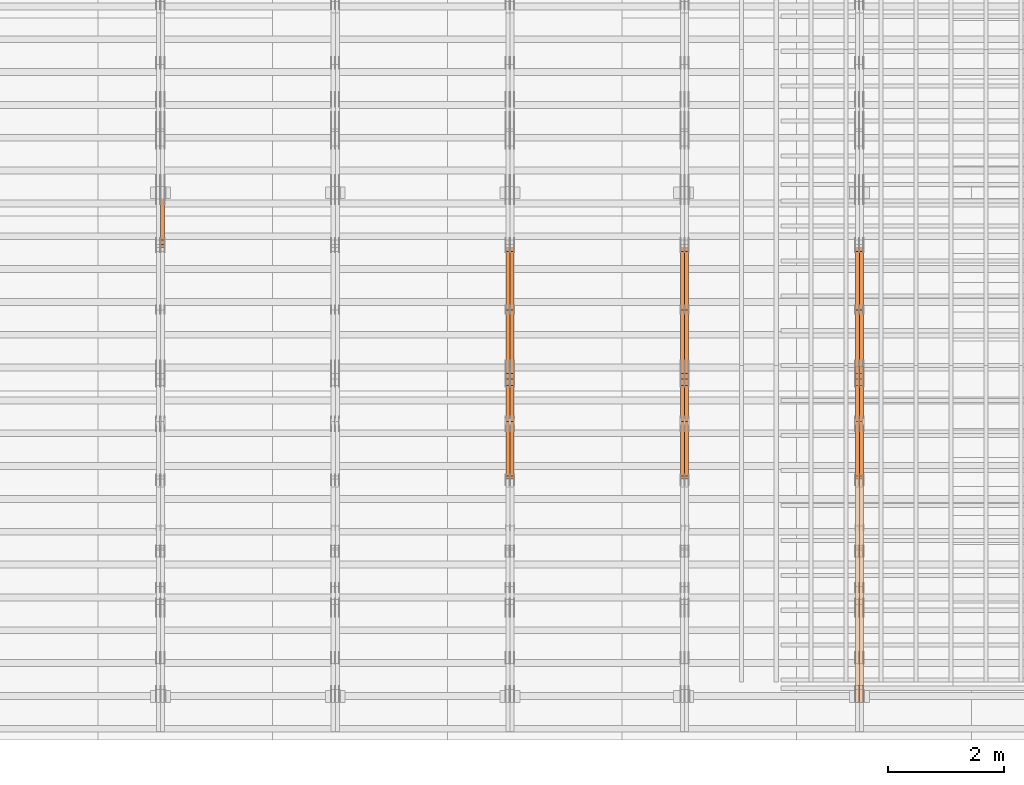
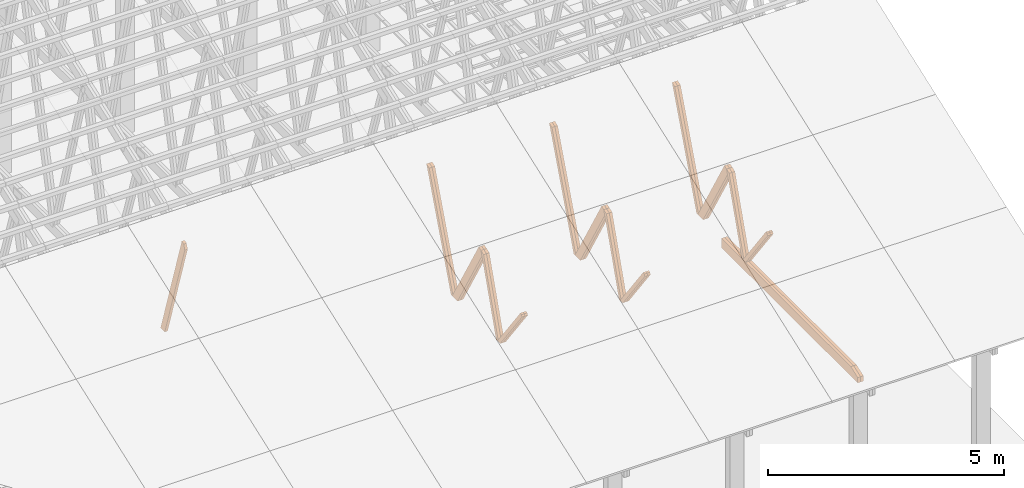
# One storey, part 48 of 189: 27 proxies.
"""IFC2X3 building model written with IfcOpenShell, lengths in millimetres."""

import ifcopenshell
import ifcopenshell.guid

model = None  # the IFC model being written
_history = None  # IfcOwnerHistory: only IFC2X3 demands one
_inside = {}  # id of a spatial element -> (the spatial element, [elements in it])
_under = {}  # id of a project, library or spatial element -> (it, [spatial elements below it])
_declared = {}  # id of a project -> (the project, [libraries it declares])
_typed = {}  # id of a type object -> (the type object, [elements of that type])
_made_of = {}  # id of a material, layer set ... -> (it, [elements and type objects made of it])


def new_model(schema):
    """Start an empty IFC model of exactly this schema.

    Asked for "IFC4X3", IfcOpenShell would pick the latest addendum, in which some entities
    have other attributes; the version numbers below select the first issue.
    IFC2X3 requires an IfcOwnerHistory on every rooted entity: one is made here for all.
    """
    global model, _history
    if schema == "IFC4X3":
        model = ifcopenshell.file(schema_version=(4, 3, 0, 0))
    else:
        model = ifcopenshell.file(schema=schema)
    _inside.clear()
    _under.clear()
    _declared.clear()
    _typed.clear()
    _made_of.clear()
    _history = None
    if model.schema == "IFC2X3":
        org = make("IfcOrganization", Name="unknown")
        user = make(
            "IfcPersonAndOrganization",
            ThePerson=make("IfcPerson", FamilyName="unknown"),
            TheOrganization=org,
        )
        app = make(
            "IfcApplication",
            ApplicationDeveloper=org,
            Version="unknown",
            ApplicationFullName="unknown",
            ApplicationIdentifier="unknown",
        )
        _history = make(
            "IfcOwnerHistory",
            OwningUser=user,
            OwningApplication=app,
            ChangeAction="ADDED",
            CreationDate=0,
        )
    return model


def make(cls, **values):
    """One entity of the class cls with the attributes given. An attribute that is None is left unset."""
    return model.create_entity(
        cls, **{name: value for name, value in values.items() if value is not None}
    )


def entity(cls, *values):
    """Any entity or typed value of the class cls, its attributes in the order of the schema. None: left unset."""
    e = model.create_entity(cls)
    for i, value in enumerate(values):
        if value is not None:
            e[i] = value
    return e


def rooted(cls, **values):
    """An entity with a GlobalId (a new one), such as an element, a storey or a relation."""
    return make(cls, GlobalId=ifcopenshell.guid.new(), OwnerHistory=_history, **values)


def si_unit(unit_type, name, prefix=None):
    """IfcSIUnit, for example si_unit("LENGTHUNIT", "METRE", prefix="MILLI")."""
    return make("IfcSIUnit", UnitType=unit_type, Prefix=prefix, Name=name)


def converted_unit(unit_type, name, factor, base, dimensions=None, offset=None):
    """IfcConversionBasedUnit, such as the inch: factor (a typed value) times the base unit."""
    return make(
        "IfcConversionBasedUnit"
        if offset is None
        else "IfcConversionBasedUnitWithOffset",
        ConversionOffset=offset,
        Dimensions=None
        if dimensions is None
        else entity("IfcDimensionalExponents", *dimensions),
        UnitType=unit_type,
        Name=name,
        ConversionFactor=make(
            "IfcMeasureWithUnit", ValueComponent=factor, UnitComponent=base
        ),
    )


def derived_unit(unit_type, elements):
    """IfcDerivedUnit: a product of units, each with its exponent."""
    return make(
        "IfcDerivedUnit",
        Elements=[
            make("IfcDerivedUnitElement", Unit=unit, Exponent=power)
            for unit, power in elements
        ],
        UnitType=unit_type,
    )


def assignment(units):
    """IfcUnitAssignment: the units of a project."""
    return None if units is None else make("IfcUnitAssignment", Units=units)


def point(xyz):
    """IfcCartesianPoint."""
    return None if xyz is None else make("IfcCartesianPoint", Coordinates=xyz)


def direction(xyz):
    """IfcDirection."""
    return None if xyz is None else make("IfcDirection", DirectionRatios=xyz)


def frame(location, z_axis=None, x_axis=None):
    """IfcAxis2Placement3D, a coordinate frame: its origin and axes. An axis left out is left unset."""
    return make(
        "IfcAxis2Placement3D",
        Location=point(location),
        Axis=direction(z_axis),
        RefDirection=direction(x_axis),
    )


def origin():
    """The frame at (0, 0, 0) with its axes left unset."""
    return frame((0.0, 0.0, 0.0))


def place(relative_to, where):
    """IfcLocalPlacement: puts the frame where relative to a parent placement (None: the world)."""
    return make(
        "IfcLocalPlacement", PlacementRelTo=relative_to, RelativePlacement=where
    )


def context(
    kind, dimensions, precision=None, world=None, true_north=None, identifier=None
):
    """IfcGeometricRepresentationContext, for example the 3D "Model" context."""
    return make(
        "IfcGeometricRepresentationContext",
        ContextIdentifier=identifier,
        ContextType=kind,
        CoordinateSpaceDimension=dimensions,
        Precision=precision,
        WorldCoordinateSystem=world,
        TrueNorth=true_north,
    )


def subcontext(parent, identifier, kind, view, scale=None):
    """IfcGeometricRepresentationSubContext, for example "Body" below "Model"."""
    return make(
        "IfcGeometricRepresentationSubContext",
        ContextIdentifier=identifier,
        ContextType=kind,
        ParentContext=parent,
        TargetScale=scale,
        TargetView=view,
    )


def project(units=None, contexts=None):
    """IfcProject with its units and contexts."""
    return rooted(
        "IfcProject",
        Name="project",
        RepresentationContexts=contexts,
        UnitsInContext=assignment(units),
    )


def spatial(cls, under=None, at=None, **own):
    """A site, building, storey or space (cls), placed at a placement, below another one or the project."""
    s = rooted(cls, ObjectPlacement=at, **own)
    if under is not None:
        _under.setdefault(under.id(), (under, []))[1].append(s)
    return s


def polyline(points):
    """IfcPolyline through the points."""
    return make("IfcPolyline", Points=[point(p) for p in points])


def outline(outer, holes=None, kind="AREA"):
    """IfcArbitraryClosedProfileDef: a profile drawn as a closed curve; with holes, ...WithVoids."""
    if holes is None:
        return make("IfcArbitraryClosedProfileDef", ProfileType=kind, OuterCurve=outer)
    return make(
        "IfcArbitraryProfileDefWithVoids",
        ProfileType=kind,
        OuterCurve=outer,
        InnerCurves=holes,
    )


def extrude(swept, where, along, depth):
    """IfcExtrudedAreaSolid: the profile swept, set in the frame where, extruded along a direction by depth."""
    return make(
        "IfcExtrudedAreaSolid",
        SweptArea=swept,
        Position=where,
        ExtrudedDirection=direction(along),
        Depth=depth,
    )


def shape(context_of_items, identifier, shape_type, items):
    """IfcShapeRepresentation: the items that make up one representation, for example the "Body"."""
    return make(
        "IfcShapeRepresentation",
        ContextOfItems=context_of_items,
        RepresentationIdentifier=identifier,
        RepresentationType=shape_type,
        Items=items,
    )


def source(mapping_origin, context_of_items, identifier, shape_type, items):
    """IfcRepresentationMap: a shape defined once, which mapped items show again and again."""
    return make(
        "IfcRepresentationMap",
        MappingOrigin=mapping_origin,
        MappedRepresentation=shape(context_of_items, identifier, shape_type, items),
    )


def transform(
    local_origin,
    x_axis=None,
    y_axis=None,
    z_axis=None,
    scale=None,
    scale2=None,
    scale3=None,
    uniform=True,
):
    """IfcCartesianTransformationOperator3D, or its non-uniform kind. x_axis, y_axis, z_axis: its Axis1, 2, 3."""
    if uniform:
        return make(
            "IfcCartesianTransformationOperator3D",
            Axis1=direction(x_axis),
            Axis2=direction(y_axis),
            LocalOrigin=point(local_origin),
            Scale=scale,
            Axis3=direction(z_axis),
        )
    return make(
        "IfcCartesianTransformationOperator3DnonUniform",
        Axis1=direction(x_axis),
        Axis2=direction(y_axis),
        LocalOrigin=point(local_origin),
        Scale=scale,
        Axis3=direction(z_axis),
        Scale2=scale2,
        Scale3=scale3,
    )


def mapped(mapping_source, mapping_target):
    """IfcMappedItem: shows the shape of a source again, moved by a transform."""
    return make(
        "IfcMappedItem", MappingSource=mapping_source, MappingTarget=mapping_target
    )


def material(Name=None, Category=None):
    """IfcMaterial."""
    return make("IfcMaterial", Name=Name, Category=Category)


def made_of(thing, what):
    """Note that an element or type object is made of a material, layer set ...; save() writes the relation."""
    if what is not None:
        _made_of.setdefault(what.id(), (what, []))[1].append(thing)
    return thing


def type_object(cls, material=None, **own):
    """A type object (cls), such as IfcWallType, which elements share."""
    return made_of(rooted(cls, **own), material)


def type_shapes(of_type, sources):
    """Give a type object the sources (RepresentationMaps) that its elements show as mapped items."""
    of_type.RepresentationMaps = sources


def element(
    cls,
    number,
    at=None,
    inside=None,
    cuts=None,
    type_object=None,
    material=None,
    context=None,
    identifier="Body",
    shape_type=None,
    held_by="IfcProductDefinitionShape",
    body=None,
    shapes=None,
    **own,
):
    """One element of the class cls, such as IfcWall. Its Tag is "e" and its number.

    at: its placement. inside: the storey or other place that contains it. cuts: it is an
    opening in that element (IfcRelVoidsElement). A single representation is given by context,
    identifier, shape_type and body (its items); several are given by shapes. held_by: the class
    of the entity that holds the representations. save() writes the other relations.
    """
    e = rooted(cls, Tag="e%d" % number, ObjectPlacement=at, **own)
    if body is not None:
        shapes = [shape(context, identifier, shape_type, body)]
    if shapes is not None:
        e.Representation = make(held_by, Representations=shapes)
    if inside is not None:
        _inside.setdefault(inside.id(), (inside, []))[1].append(e)
    if cuts is not None:
        rooted(
            "IfcRelVoidsElement", RelatingBuildingElement=cuts, RelatedOpeningElement=e
        )
    if type_object is not None:
        _typed.setdefault(type_object.id(), (type_object, []))[1].append(e)
    return made_of(e, material)


def aggregate(whole, parts):
    """IfcRelAggregates: a whole, such as a stair, and the parts it consists of."""
    return rooted("IfcRelAggregates", RelatingObject=whole, RelatedObjects=parts)


def save(model, path):
    """Write the relations noted so far, then the file.

    IfcRelAggregates (storeys below a building ...), IfcRelContainedInSpatialStructure (elements
    in a storey), IfcRelDefinesByType, IfcRelAssociatesMaterial and IfcRelDeclares: one each for
    every whole, place, type object, material and project.
    """
    for whole, parts in _under.values():
        aggregate(whole, parts)
    for where, things in _inside.values():
        rooted(
            "IfcRelContainedInSpatialStructure",
            RelatedElements=things,
            RelatingStructure=where,
        )
    for kind, things in _typed.values():
        rooted("IfcRelDefinesByType", RelatedObjects=things, RelatingType=kind)
    for what, things in _made_of.values():
        rooted("IfcRelAssociatesMaterial", RelatedObjects=things, RelatingMaterial=what)
    for by, libraries in _declared.values():
        rooted("IfcRelDeclares", RelatingContext=by, RelatedDefinitions=libraries)
    model.write(path)


model = new_model("IFC2X3")

# Units and contexts
model_context = context("Model", 3, precision=0.01, world=origin(), true_north=direction((6.12303176911189e-17, 1.0)))
body_context = subcontext(model_context, "Body", "Model", "MODEL_VIEW")
ifc_project = project(units=[si_unit("LENGTHUNIT", "METRE", prefix="MILLI"), si_unit("AREAUNIT", "SQUARE_METRE"), si_unit("VOLUMEUNIT", "CUBIC_METRE"), converted_unit("PLANEANGLEUNIT", "DEGREE", entity("IfcRatioMeasure", 0.0174532925199433), si_unit("PLANEANGLEUNIT", "RADIAN"), dimensions=[0, 0, 0, 0, 0, 0, 0]), si_unit("MASSUNIT", "GRAM", prefix="KILO"), derived_unit("MASSDENSITYUNIT", [(si_unit("MASSUNIT", "GRAM", prefix="KILO"), 1), (si_unit("LENGTHUNIT", "METRE"), -3)]), si_unit("TIMEUNIT", "SECOND"), si_unit("FREQUENCYUNIT", "HERTZ"), si_unit("THERMODYNAMICTEMPERATUREUNIT", "DEGREE_CELSIUS"), derived_unit("THERMALTRANSMITTANCEUNIT", [(si_unit("MASSUNIT", "GRAM", prefix="KILO"), 1), (si_unit("THERMODYNAMICTEMPERATUREUNIT", "KELVIN"), -1), (si_unit("TIMEUNIT", "SECOND"), -3)]), derived_unit("VOLUMETRICFLOWRATEUNIT", [(si_unit("LENGTHUNIT", "METRE"), 3), (si_unit("TIMEUNIT", "SECOND"), -1)]), si_unit("ELECTRICCURRENTUNIT", "AMPERE"), si_unit("ELECTRICVOLTAGEUNIT", "VOLT"), si_unit("POWERUNIT", "WATT"), si_unit("FORCEUNIT", "NEWTON"), si_unit("ILLUMINANCEUNIT", "LUX"), si_unit("LUMINOUSFLUXUNIT", "LUMEN"), si_unit("LUMINOUSINTENSITYUNIT", "CANDELA"), derived_unit("USERDEFINED", [(si_unit("MASSUNIT", "GRAM", prefix="KILO"), -1), (si_unit("LENGTHUNIT", "METRE"), -2), (si_unit("TIMEUNIT", "SECOND"), 3), (si_unit("LUMINOUSFLUXUNIT", "LUMEN"), 1)]), derived_unit("LINEARVELOCITYUNIT", [(si_unit("LENGTHUNIT", "METRE"), 1), (si_unit("TIMEUNIT", "SECOND"), -1)]), si_unit("PRESSUREUNIT", "PASCAL"), derived_unit("USERDEFINED", [(si_unit("LENGTHUNIT", "METRE"), -2), (si_unit("MASSUNIT", "GRAM", prefix="KILO"), 1), (si_unit("TIMEUNIT", "SECOND"), -2)])], contexts=[model_context])

# Site, building, storey
site_placement = place(None, origin())
site = spatial("IfcSite", under=ifc_project, at=site_placement, CompositionType="ELEMENT")
building_placement = place(site_placement, origin())
building = spatial("IfcBuilding", under=site, at=building_placement, CompositionType="ELEMENT")
storey_placement = place(building_placement, origin())
storey = spatial("IfcBuildingStorey", under=building, at=storey_placement, Name="Default", CompositionType="ELEMENT", Elevation=0.0)

# Proxies
ifc_material_1 = material(Name="IfcSurfaceStyle #240740")
building_element_proxy_type_1 = type_object("IfcBuildingElementProxyType", Name="T1-W8 240738", PredefinedType="NOTDEFINED", material=ifc_material_1)
shared_shape_1 = source(origin(), body_context, "Body", "SweptSolid", [
    extrude(outline(polyline([(-1781.70529904483, -47.500320228718), (1161.65050357787, -47.5003202287179), (1179.56135870849, 0.000731866266039397), (1140.6022069428, 47.4998218997103), (-1700.10877018433, 47.5000866914596), (-1781.70529904483, -47.500320228718)])), frame((1179.56135870869, 47.5007236522113, 0.0), z_axis=(0.0, 0.0, 1.0), x_axis=(-1.0, 3.74658825645258e-07, 0.0)), (0.0, 0.0, 1.0), 69.9999999999998),
])
type_shapes(building_element_proxy_type_1, [shared_shape_1])
proxy_1_placement = place(building_placement, frame((45300.0, 6723.5697965901, 261.758864533503), z_axis=(-1.0, 0.0, 0.0), x_axis=(0.0, 0.352814979177603, 0.93569310698963)))
element("IfcBuildingElementProxy", 1, at=proxy_1_placement, inside=storey, type_object=building_element_proxy_type_1, material=ifc_material_1, Name="T1-W8", context=body_context, shape_type="MappedRepresentation", body=[
    mapped(shared_shape_1, transform((0.0, 0.0, 0.0), scale=1.0)),
])
ifc_material_2 = material(Name="IfcSurfaceStyle #240674")
building_element_proxy_type_2 = type_object("IfcBuildingElementProxyType", Name="T1-W8 240672", PredefinedType="NOTDEFINED", material=ifc_material_2)
shared_shape_2 = source(origin(), body_context, "Body", "SweptSolid", [
    extrude(outline(polyline([(-1781.70529904483, -47.500320228718), (1161.65050357787, -47.5003202287179), (1179.56135870849, 0.000731866266039397), (1140.6022069428, 47.4998218997103), (-1700.10877018433, 47.5000866914596), (-1781.70529904483, -47.500320228718)])), frame((1179.56135870869, 47.5007236522113, 0.0), z_axis=(0.0, 0.0, 1.0), x_axis=(-1.0, 3.74658825645258e-07, 0.0)), (0.0, 0.0, 1.0), 69.9999999999998),
])
type_shapes(building_element_proxy_type_2, [shared_shape_2])
proxy_2_placement = place(building_placement, frame((45230.0, 6723.5697965901, 261.758864533503), z_axis=(-1.0, 0.0, 0.0), x_axis=(0.0, 0.352814979177603, 0.93569310698963)))
element("IfcBuildingElementProxy", 2, at=proxy_2_placement, inside=storey, type_object=building_element_proxy_type_2, material=ifc_material_2, Name="T1-W8", context=body_context, shape_type="MappedRepresentation", body=[
    mapped(shared_shape_2, transform((0.0, 0.0, 0.0), scale=1.0)),
])
ifc_material_3 = material(Name="IfcSurfaceStyle #240476")
building_element_proxy_type_3 = type_object("IfcBuildingElementProxyType", Name="T1-W2 240474", PredefinedType="NOTDEFINED", material=ifc_material_3)
shared_shape_3 = source(origin(), body_context, "Body", "SweptSolid", [
    extrude(outline(polyline([(-765.033104991319, -1130.91940266317), (-539.905732758898, -1130.91940266317), (493.678280567457, 660.584515081422), (452.144945212405, 783.697385511457), (359.115611970356, 817.556904733455), (-765.033104991319, -1130.91940266317)])), frame((904.774360566371, 97.5002668805543, 0.0), z_axis=(0.0, 0.0, 1.0), x_axis=(-0.499731715721184, 0.866180242387438, 0.0)), (0.0, 0.0, 1.0), 69.9999999999998),
])
type_shapes(building_element_proxy_type_3, [shared_shape_3])
proxy_3_placement = place(building_placement, frame((45300.0, 5635.28919163287, 2208.3400784451), z_axis=(-1.0, 0.0, 0.0), x_axis=(0.0, 0.5, -0.866025403784439)))
element("IfcBuildingElementProxy", 3, at=proxy_3_placement, inside=storey, type_object=building_element_proxy_type_3, material=ifc_material_3, Name="T1-W2", context=body_context, shape_type="MappedRepresentation", body=[
    mapped(shared_shape_3, transform((0.0, 0.0, 0.0), scale=1.0)),
])
ifc_material_4 = material(Name="IfcSurfaceStyle #240410")
building_element_proxy_type_4 = type_object("IfcBuildingElementProxyType", Name="T1-W2 240408", PredefinedType="NOTDEFINED", material=ifc_material_4)
shared_shape_4 = source(origin(), body_context, "Body", "SweptSolid", [
    extrude(outline(polyline([(-765.033104991319, -1130.91940266317), (-539.905732758898, -1130.91940266317), (493.678280567457, 660.584515081422), (452.144945212405, 783.697385511457), (359.115611970356, 817.556904733455), (-765.033104991319, -1130.91940266317)])), frame((904.774360566371, 97.5002668805543, 0.0), z_axis=(0.0, 0.0, 1.0), x_axis=(-0.499731715721184, 0.866180242387438, 0.0)), (0.0, 0.0, 1.0), 69.9999999999998),
])
type_shapes(building_element_proxy_type_4, [shared_shape_4])
proxy_4_placement = place(building_placement, frame((45230.0, 5635.28919163287, 2208.3400784451), z_axis=(-1.0, 0.0, 0.0), x_axis=(0.0, 0.5, -0.866025403784439)))
element("IfcBuildingElementProxy", 4, at=proxy_4_placement, inside=storey, type_object=building_element_proxy_type_4, material=ifc_material_4, Name="T1-W2", context=body_context, shape_type="MappedRepresentation", body=[
    mapped(shared_shape_4, transform((0.0, 0.0, 0.0), scale=1.0)),
])
ifc_material_5 = material(Name="IfcSurfaceStyle #240212")
building_element_proxy_type_5 = type_object("IfcBuildingElementProxyType", Name="T1-W9 240210", PredefinedType="NOTDEFINED", material=ifc_material_5)
shared_shape_5 = source(origin(), body_context, "Body", "SweptSolid", [
    extrude(outline(polyline([(-1227.3969292634, -47.5000382896404), (793.242467803064, -47.5000382896404), (809.267705296822, 1.0956605530188e-05), (776.329919980315, 47.5000328113376), (-1151.4431638168, 47.5000328113376), (-1227.3969292634, -47.5000382896404)])), frame((809.267705296822, 47.5000328113376, 0.0), z_axis=(0.0, 0.0, 1.0), x_axis=(-1.0, 0.0, 0.0)), (0.0, 0.0, 1.0), 69.9999999999999),
])
type_shapes(building_element_proxy_type_5, [shared_shape_5])
proxy_5_placement = place(building_placement, frame((45300.0, 4809.76380889125, 260.184242613649), z_axis=(-1.0, 0.0, 0.0), x_axis=(0.0, 0.31966811847134, 0.947529574226047)))
element("IfcBuildingElementProxy", 5, at=proxy_5_placement, inside=storey, type_object=building_element_proxy_type_5, material=ifc_material_5, Name="T1-W9", context=body_context, shape_type="MappedRepresentation", body=[
    mapped(shared_shape_5, transform((0.0, 0.0, 0.0), scale=1.0)),
])
ifc_material_6 = material(Name="IfcSurfaceStyle #240146")
building_element_proxy_type_6 = type_object("IfcBuildingElementProxyType", Name="T1-W9 240144", PredefinedType="NOTDEFINED", material=ifc_material_6)
shared_shape_6 = source(origin(), body_context, "Body", "SweptSolid", [
    extrude(outline(polyline([(-1227.3969292634, -47.5000382896404), (793.242467803064, -47.5000382896404), (809.267705296822, 1.0956605530188e-05), (776.329919980315, 47.5000328113376), (-1151.4431638168, 47.5000328113376), (-1227.3969292634, -47.5000382896404)])), frame((809.267705296822, 47.5000328113376, 0.0), z_axis=(0.0, 0.0, 1.0), x_axis=(-1.0, 0.0, 0.0)), (0.0, 0.0, 1.0), 69.9999999999999),
])
type_shapes(building_element_proxy_type_6, [shared_shape_6])
proxy_6_placement = place(building_placement, frame((45230.0, 4809.76380889125, 260.184242613649), z_axis=(-1.0, 0.0, 0.0), x_axis=(0.0, 0.31966811847134, 0.947529574226047)))
element("IfcBuildingElementProxy", 6, at=proxy_6_placement, inside=storey, type_object=building_element_proxy_type_6, material=ifc_material_6, Name="T1-W9", context=body_context, shape_type="MappedRepresentation", body=[
    mapped(shared_shape_6, transform((0.0, 0.0, 0.0), scale=1.0)),
])
ifc_material_7 = material(Name="IfcSurfaceStyle #239948")
building_element_proxy_type_7 = type_object("IfcBuildingElementProxyType", Name="T1-W10 239946", PredefinedType="NOTDEFINED", material=ifc_material_7)
shared_shape_7 = source(origin(), body_context, "Body", "SweptSolid", [
    extrude(outline(polyline([(-922.639472665691, -47.5001890573134), (629.920966338637, -47.5001890573134), (650.067737483374, 0.000694680531158376), (635.89112756682, 47.4998417170478), (-993.240358723139, 47.4998417170478), (-922.639472665691, -47.5001890573134)])), frame((650.068202545693, 47.4999816623145, 0.0), z_axis=(0.0, 0.0, 1.0), x_axis=(-1.0, 0.0, 0.0)), (0.0, 0.0, 1.0), 69.9999999999999),
])
type_shapes(building_element_proxy_type_7, [shared_shape_7])
proxy_7_placement = place(building_placement, frame((45300.0, 3874.56126239818, 1563.95828147518), z_axis=(-1.0, 0.0, 0.0), x_axis=(0.0, 0.596486092002, -0.802623412347398)))
element("IfcBuildingElementProxy", 7, at=proxy_7_placement, inside=storey, type_object=building_element_proxy_type_7, material=ifc_material_7, Name="T1-W10", context=body_context, shape_type="MappedRepresentation", body=[
    mapped(shared_shape_7, transform((0.0, 0.0, 0.0), scale=1.0)),
])
ifc_material_8 = material(Name="IfcSurfaceStyle #239882")
building_element_proxy_type_8 = type_object("IfcBuildingElementProxyType", Name="T1-W10 239880", PredefinedType="NOTDEFINED", material=ifc_material_8)
shared_shape_8 = source(origin(), body_context, "Body", "SweptSolid", [
    extrude(outline(polyline([(-922.639472665691, -47.5001890573134), (629.920966338637, -47.5001890573134), (650.067737483374, 0.000694680531158376), (635.89112756682, 47.4998417170478), (-993.240358723139, 47.4998417170478), (-922.639472665691, -47.5001890573134)])), frame((650.068202545693, 47.4999816623145, 0.0), z_axis=(0.0, 0.0, 1.0), x_axis=(-1.0, 0.0, 0.0)), (0.0, 0.0, 1.0), 69.9999999999999),
])
type_shapes(building_element_proxy_type_8, [shared_shape_8])
proxy_8_placement = place(building_placement, frame((45230.0, 3874.56126239818, 1563.95828147518), z_axis=(-1.0, 0.0, 0.0), x_axis=(0.0, 0.596486092002, -0.802623412347398)))
element("IfcBuildingElementProxy", 8, at=proxy_8_placement, inside=storey, type_object=building_element_proxy_type_8, material=ifc_material_8, Name="T1-W10", context=body_context, shape_type="MappedRepresentation", body=[
    mapped(shared_shape_8, transform((0.0, 0.0, 0.0), scale=1.0)),
])
ifc_material_9 = material(Name="IfcSurfaceStyle #237812")
building_element_proxy_type_9 = type_object("IfcBuildingElementProxyType", Name="T1-B2 237810", PredefinedType="NOTDEFINED", material=ifc_material_9)
shared_shape_9 = source(origin(), body_context, "Body", "SweptSolid", [
    extrude(outline(polyline([(-3399.385546875, -125.855288696291), (2363.08125, -125.855288696291), (2363.08125, 13.4211547851572), (2072.60859375, 119.144711303712), (-3399.385546875, 119.144711303712), (-3399.385546875, -125.855288696291)])), frame((2363.08125, 119.144711303712, 0.0), z_axis=(0.0, 0.0, 1.0), x_axis=(-1.0, 0.0, 0.0)), (0.0, 0.0, 1.0), 69.9999999999997),
])
type_shapes(building_element_proxy_type_9, [shared_shape_9])
proxy_9_placement = place(building_placement, frame((45300.0, 0.0, 245.0), z_axis=(-1.0, 0.0, 0.0), x_axis=(0.0, 1.0, 0.0)))
element("IfcBuildingElementProxy", 9, at=proxy_9_placement, inside=storey, type_object=building_element_proxy_type_9, material=ifc_material_9, Name="T1-B2", context=body_context, shape_type="MappedRepresentation", body=[
    mapped(shared_shape_9, transform((0.0, 0.0, 0.0), scale=1.0)),
])
ifc_material_10 = material(Name="IfcSurfaceStyle #237746")
building_element_proxy_type_10 = type_object("IfcBuildingElementProxyType", Name="T1-B2 237744", PredefinedType="NOTDEFINED", material=ifc_material_10)
shared_shape_10 = source(origin(), body_context, "Body", "SweptSolid", [
    extrude(outline(polyline([(-3399.385546875, -125.855288696291), (2363.08125, -125.855288696291), (2363.08125, 13.4211547851572), (2072.60859375, 119.144711303712), (-3399.385546875, 119.144711303712), (-3399.385546875, -125.855288696291)])), frame((2363.08125, 119.144711303712, 0.0), z_axis=(0.0, 0.0, 1.0), x_axis=(-1.0, 0.0, 0.0)), (0.0, 0.0, 1.0), 69.9999999999997),
])
type_shapes(building_element_proxy_type_10, [shared_shape_10])
proxy_10_placement = place(building_placement, frame((45230.0, 0.0, 245.0), z_axis=(-1.0, 0.0, 0.0), x_axis=(0.0, 1.0, 0.0)))
element("IfcBuildingElementProxy", 10, at=proxy_10_placement, inside=storey, type_object=building_element_proxy_type_10, material=ifc_material_10, Name="T1-B2", context=body_context, shape_type="MappedRepresentation", body=[
    mapped(shared_shape_10, transform((0.0, 0.0, 0.0), scale=1.0)),
])
ifc_material_11 = material(Name="IfcSurfaceStyle #224950")
building_element_proxy_type_11 = type_object("IfcBuildingElementProxyType", Name="T1-W8 224948", PredefinedType="NOTDEFINED", material=ifc_material_11)
shared_shape_11 = source(origin(), body_context, "Body", "SweptSolid", [
    extrude(outline(polyline([(-1781.70529904483, -47.500320228718), (1161.65050357787, -47.5003202287179), (1179.56135870849, 0.000731866266039397), (1140.6022069428, 47.4998218997103), (-1700.10877018433, 47.5000866914596), (-1781.70529904483, -47.500320228718)])), frame((1179.56135870869, 47.5007236522113, 0.0), z_axis=(0.0, 0.0, 1.0), x_axis=(-1.0, 3.74658825645258e-07, 0.0)), (0.0, 0.0, 1.0), 69.9999999999998),
])
type_shapes(building_element_proxy_type_11, [shared_shape_11])
proxy_11_placement = place(building_placement, frame((42300.0, 6723.5697965901, 261.758864533503), z_axis=(-1.0, 0.0, 0.0), x_axis=(0.0, 0.352814979177603, 0.93569310698963)))
element("IfcBuildingElementProxy", 11, at=proxy_11_placement, inside=storey, type_object=building_element_proxy_type_11, material=ifc_material_11, Name="T1-W8", context=body_context, shape_type="MappedRepresentation", body=[
    mapped(shared_shape_11, transform((0.0, 0.0, 0.0), scale=1.0)),
])
ifc_material_12 = material(Name="IfcSurfaceStyle #224884")
building_element_proxy_type_12 = type_object("IfcBuildingElementProxyType", Name="T1-W8 224882", PredefinedType="NOTDEFINED", material=ifc_material_12)
shared_shape_12 = source(origin(), body_context, "Body", "SweptSolid", [
    extrude(outline(polyline([(-1781.70529904483, -47.500320228718), (1161.65050357787, -47.5003202287179), (1179.56135870849, 0.000731866266039397), (1140.6022069428, 47.4998218997103), (-1700.10877018433, 47.5000866914596), (-1781.70529904483, -47.500320228718)])), frame((1179.56135870869, 47.5007236522113, 0.0), z_axis=(0.0, 0.0, 1.0), x_axis=(-1.0, 3.74658825645258e-07, 0.0)), (0.0, 0.0, 1.0), 69.9999999999998),
])
type_shapes(building_element_proxy_type_12, [shared_shape_12])
proxy_12_placement = place(building_placement, frame((42230.0, 6723.5697965901, 261.758864533503), z_axis=(-1.0, 0.0, 0.0), x_axis=(0.0, 0.352814979177603, 0.93569310698963)))
element("IfcBuildingElementProxy", 12, at=proxy_12_placement, inside=storey, type_object=building_element_proxy_type_12, material=ifc_material_12, Name="T1-W8", context=body_context, shape_type="MappedRepresentation", body=[
    mapped(shared_shape_12, transform((0.0, 0.0, 0.0), scale=1.0)),
])
ifc_material_13 = material(Name="IfcSurfaceStyle #224686")
building_element_proxy_type_13 = type_object("IfcBuildingElementProxyType", Name="T1-W2 224684", PredefinedType="NOTDEFINED", material=ifc_material_13)
shared_shape_13 = source(origin(), body_context, "Body", "SweptSolid", [
    extrude(outline(polyline([(-765.033104991319, -1130.91940266317), (-539.905732758898, -1130.91940266317), (493.678280567457, 660.584515081422), (452.144945212405, 783.697385511457), (359.115611970356, 817.556904733455), (-765.033104991319, -1130.91940266317)])), frame((904.774360566371, 97.5002668805543, 0.0), z_axis=(0.0, 0.0, 1.0), x_axis=(-0.499731715721184, 0.866180242387438, 0.0)), (0.0, 0.0, 1.0), 69.9999999999998),
])
type_shapes(building_element_proxy_type_13, [shared_shape_13])
proxy_13_placement = place(building_placement, frame((42300.0, 5635.28919163287, 2208.3400784451), z_axis=(-1.0, 0.0, 0.0), x_axis=(0.0, 0.5, -0.866025403784439)))
element("IfcBuildingElementProxy", 13, at=proxy_13_placement, inside=storey, type_object=building_element_proxy_type_13, material=ifc_material_13, Name="T1-W2", context=body_context, shape_type="MappedRepresentation", body=[
    mapped(shared_shape_13, transform((0.0, 0.0, 0.0), scale=1.0)),
])
ifc_material_14 = material(Name="IfcSurfaceStyle #224620")
building_element_proxy_type_14 = type_object("IfcBuildingElementProxyType", Name="T1-W2 224618", PredefinedType="NOTDEFINED", material=ifc_material_14)
shared_shape_14 = source(origin(), body_context, "Body", "SweptSolid", [
    extrude(outline(polyline([(-765.033104991319, -1130.91940266317), (-539.905732758898, -1130.91940266317), (493.678280567457, 660.584515081422), (452.144945212405, 783.697385511457), (359.115611970356, 817.556904733455), (-765.033104991319, -1130.91940266317)])), frame((904.774360566371, 97.5002668805543, 0.0), z_axis=(0.0, 0.0, 1.0), x_axis=(-0.499731715721184, 0.866180242387438, 0.0)), (0.0, 0.0, 1.0), 69.9999999999998),
])
type_shapes(building_element_proxy_type_14, [shared_shape_14])
proxy_14_placement = place(building_placement, frame((42230.0, 5635.28919163287, 2208.3400784451), z_axis=(-1.0, 0.0, 0.0), x_axis=(0.0, 0.5, -0.866025403784439)))
element("IfcBuildingElementProxy", 14, at=proxy_14_placement, inside=storey, type_object=building_element_proxy_type_14, material=ifc_material_14, Name="T1-W2", context=body_context, shape_type="MappedRepresentation", body=[
    mapped(shared_shape_14, transform((0.0, 0.0, 0.0), scale=1.0)),
])
ifc_material_15 = material(Name="IfcSurfaceStyle #224422")
building_element_proxy_type_15 = type_object("IfcBuildingElementProxyType", Name="T1-W9 224420", PredefinedType="NOTDEFINED", material=ifc_material_15)
shared_shape_15 = source(origin(), body_context, "Body", "SweptSolid", [
    extrude(outline(polyline([(-1227.3969292634, -47.5000382896404), (793.242467803064, -47.5000382896404), (809.267705296822, 1.0956605530188e-05), (776.329919980315, 47.5000328113376), (-1151.4431638168, 47.5000328113376), (-1227.3969292634, -47.5000382896404)])), frame((809.267705296822, 47.5000328113376, 0.0), z_axis=(0.0, 0.0, 1.0), x_axis=(-1.0, 0.0, 0.0)), (0.0, 0.0, 1.0), 69.9999999999999),
])
type_shapes(building_element_proxy_type_15, [shared_shape_15])
proxy_15_placement = place(building_placement, frame((42300.0, 4809.76380889125, 260.184242613649), z_axis=(-1.0, 0.0, 0.0), x_axis=(0.0, 0.31966811847134, 0.947529574226047)))
element("IfcBuildingElementProxy", 15, at=proxy_15_placement, inside=storey, type_object=building_element_proxy_type_15, material=ifc_material_15, Name="T1-W9", context=body_context, shape_type="MappedRepresentation", body=[
    mapped(shared_shape_15, transform((0.0, 0.0, 0.0), scale=1.0)),
])
ifc_material_16 = material(Name="IfcSurfaceStyle #224356")
building_element_proxy_type_16 = type_object("IfcBuildingElementProxyType", Name="T1-W9 224354", PredefinedType="NOTDEFINED", material=ifc_material_16)
shared_shape_16 = source(origin(), body_context, "Body", "SweptSolid", [
    extrude(outline(polyline([(-1227.3969292634, -47.5000382896404), (793.242467803064, -47.5000382896404), (809.267705296822, 1.0956605530188e-05), (776.329919980315, 47.5000328113376), (-1151.4431638168, 47.5000328113376), (-1227.3969292634, -47.5000382896404)])), frame((809.267705296822, 47.5000328113376, 0.0), z_axis=(0.0, 0.0, 1.0), x_axis=(-1.0, 0.0, 0.0)), (0.0, 0.0, 1.0), 69.9999999999999),
])
type_shapes(building_element_proxy_type_16, [shared_shape_16])
proxy_16_placement = place(building_placement, frame((42230.0, 4809.76380889125, 260.184242613649), z_axis=(-1.0, 0.0, 0.0), x_axis=(0.0, 0.31966811847134, 0.947529574226047)))
element("IfcBuildingElementProxy", 16, at=proxy_16_placement, inside=storey, type_object=building_element_proxy_type_16, material=ifc_material_16, Name="T1-W9", context=body_context, shape_type="MappedRepresentation", body=[
    mapped(shared_shape_16, transform((0.0, 0.0, 0.0), scale=1.0)),
])
ifc_material_17 = material(Name="IfcSurfaceStyle #224158")
building_element_proxy_type_17 = type_object("IfcBuildingElementProxyType", Name="T1-W10 224156", PredefinedType="NOTDEFINED", material=ifc_material_17)
shared_shape_17 = source(origin(), body_context, "Body", "SweptSolid", [
    extrude(outline(polyline([(-922.639472665691, -47.5001890573134), (629.920966338637, -47.5001890573134), (650.067737483374, 0.000694680531158376), (635.89112756682, 47.4998417170478), (-993.240358723139, 47.4998417170478), (-922.639472665691, -47.5001890573134)])), frame((650.068202545693, 47.4999816623145, 0.0), z_axis=(0.0, 0.0, 1.0), x_axis=(-1.0, 0.0, 0.0)), (0.0, 0.0, 1.0), 69.9999999999999),
])
type_shapes(building_element_proxy_type_17, [shared_shape_17])
proxy_17_placement = place(building_placement, frame((42300.0, 3874.56126239818, 1563.95828147518), z_axis=(-1.0, 0.0, 0.0), x_axis=(0.0, 0.596486092002, -0.802623412347398)))
element("IfcBuildingElementProxy", 17, at=proxy_17_placement, inside=storey, type_object=building_element_proxy_type_17, material=ifc_material_17, Name="T1-W10", context=body_context, shape_type="MappedRepresentation", body=[
    mapped(shared_shape_17, transform((0.0, 0.0, 0.0), scale=1.0)),
])
ifc_material_18 = material(Name="IfcSurfaceStyle #224092")
building_element_proxy_type_18 = type_object("IfcBuildingElementProxyType", Name="T1-W10 224090", PredefinedType="NOTDEFINED", material=ifc_material_18)
shared_shape_18 = source(origin(), body_context, "Body", "SweptSolid", [
    extrude(outline(polyline([(-922.639472665691, -47.5001890573134), (629.920966338637, -47.5001890573134), (650.067737483374, 0.000694680531158376), (635.89112756682, 47.4998417170478), (-993.240358723139, 47.4998417170478), (-922.639472665691, -47.5001890573134)])), frame((650.068202545693, 47.4999816623145, 0.0), z_axis=(0.0, 0.0, 1.0), x_axis=(-1.0, 0.0, 0.0)), (0.0, 0.0, 1.0), 69.9999999999999),
])
type_shapes(building_element_proxy_type_18, [shared_shape_18])
proxy_18_placement = place(building_placement, frame((42230.0, 3874.56126239818, 1563.95828147518), z_axis=(-1.0, 0.0, 0.0), x_axis=(0.0, 0.596486092002, -0.802623412347398)))
element("IfcBuildingElementProxy", 18, at=proxy_18_placement, inside=storey, type_object=building_element_proxy_type_18, material=ifc_material_18, Name="T1-W10", context=body_context, shape_type="MappedRepresentation", body=[
    mapped(shared_shape_18, transform((0.0, 0.0, 0.0), scale=1.0)),
])
ifc_material_19 = material(Name="IfcSurfaceStyle #209160")
building_element_proxy_type_19 = type_object("IfcBuildingElementProxyType", Name="T1-W8 209158", PredefinedType="NOTDEFINED", material=ifc_material_19)
shared_shape_19 = source(origin(), body_context, "Body", "SweptSolid", [
    extrude(outline(polyline([(-1781.70529904483, -47.500320228718), (1161.65050357787, -47.5003202287179), (1179.56135870849, 0.000731866266039397), (1140.6022069428, 47.4998218997103), (-1700.10877018433, 47.5000866914596), (-1781.70529904483, -47.500320228718)])), frame((1179.56135870869, 47.5007236522113, 0.0), z_axis=(0.0, 0.0, 1.0), x_axis=(-1.0, 3.74658825645258e-07, 0.0)), (0.0, 0.0, 1.0), 69.9999999999998),
])
type_shapes(building_element_proxy_type_19, [shared_shape_19])
proxy_19_placement = place(building_placement, frame((39300.0, 6723.5697965901, 261.758864533503), z_axis=(-1.0, 0.0, 0.0), x_axis=(0.0, 0.352814979177603, 0.93569310698963)))
element("IfcBuildingElementProxy", 19, at=proxy_19_placement, inside=storey, type_object=building_element_proxy_type_19, material=ifc_material_19, Name="T1-W8", context=body_context, shape_type="MappedRepresentation", body=[
    mapped(shared_shape_19, transform((0.0, 0.0, 0.0), scale=1.0)),
])
ifc_material_20 = material(Name="IfcSurfaceStyle #209094")
building_element_proxy_type_20 = type_object("IfcBuildingElementProxyType", Name="T1-W8 209092", PredefinedType="NOTDEFINED", material=ifc_material_20)
shared_shape_20 = source(origin(), body_context, "Body", "SweptSolid", [
    extrude(outline(polyline([(-1781.70529904483, -47.500320228718), (1161.65050357787, -47.5003202287179), (1179.56135870849, 0.000731866266039397), (1140.6022069428, 47.4998218997103), (-1700.10877018433, 47.5000866914596), (-1781.70529904483, -47.500320228718)])), frame((1179.56135870869, 47.5007236522113, 0.0), z_axis=(0.0, 0.0, 1.0), x_axis=(-1.0, 3.74658825645258e-07, 0.0)), (0.0, 0.0, 1.0), 69.9999999999998),
])
type_shapes(building_element_proxy_type_20, [shared_shape_20])
proxy_20_placement = place(building_placement, frame((39230.0, 6723.5697965901, 261.758864533503), z_axis=(-1.0, 0.0, 0.0), x_axis=(0.0, 0.352814979177603, 0.93569310698963)))
element("IfcBuildingElementProxy", 20, at=proxy_20_placement, inside=storey, type_object=building_element_proxy_type_20, material=ifc_material_20, Name="T1-W8", context=body_context, shape_type="MappedRepresentation", body=[
    mapped(shared_shape_20, transform((0.0, 0.0, 0.0), scale=1.0)),
])
ifc_material_21 = material(Name="IfcSurfaceStyle #208896")
building_element_proxy_type_21 = type_object("IfcBuildingElementProxyType", Name="T1-W2 208894", PredefinedType="NOTDEFINED", material=ifc_material_21)
shared_shape_21 = source(origin(), body_context, "Body", "SweptSolid", [
    extrude(outline(polyline([(-765.033104991319, -1130.91940266317), (-539.905732758898, -1130.91940266317), (493.678280567457, 660.584515081422), (452.144945212405, 783.697385511457), (359.115611970356, 817.556904733455), (-765.033104991319, -1130.91940266317)])), frame((904.774360566371, 97.5002668805543, 0.0), z_axis=(0.0, 0.0, 1.0), x_axis=(-0.499731715721184, 0.866180242387438, 0.0)), (0.0, 0.0, 1.0), 69.9999999999998),
])
type_shapes(building_element_proxy_type_21, [shared_shape_21])
proxy_21_placement = place(building_placement, frame((39300.0, 5635.28919163287, 2208.3400784451), z_axis=(-1.0, 0.0, 0.0), x_axis=(0.0, 0.5, -0.866025403784439)))
element("IfcBuildingElementProxy", 21, at=proxy_21_placement, inside=storey, type_object=building_element_proxy_type_21, material=ifc_material_21, Name="T1-W2", context=body_context, shape_type="MappedRepresentation", body=[
    mapped(shared_shape_21, transform((0.0, 0.0, 0.0), scale=1.0)),
])
ifc_material_22 = material(Name="IfcSurfaceStyle #208830")
building_element_proxy_type_22 = type_object("IfcBuildingElementProxyType", Name="T1-W2 208828", PredefinedType="NOTDEFINED", material=ifc_material_22)
shared_shape_22 = source(origin(), body_context, "Body", "SweptSolid", [
    extrude(outline(polyline([(-765.033104991319, -1130.91940266317), (-539.905732758898, -1130.91940266317), (493.678280567457, 660.584515081422), (452.144945212405, 783.697385511457), (359.115611970356, 817.556904733455), (-765.033104991319, -1130.91940266317)])), frame((904.774360566371, 97.5002668805543, 0.0), z_axis=(0.0, 0.0, 1.0), x_axis=(-0.499731715721184, 0.866180242387438, 0.0)), (0.0, 0.0, 1.0), 69.9999999999998),
])
type_shapes(building_element_proxy_type_22, [shared_shape_22])
proxy_22_placement = place(building_placement, frame((39230.0, 5635.28919163287, 2208.3400784451), z_axis=(-1.0, 0.0, 0.0), x_axis=(0.0, 0.5, -0.866025403784439)))
element("IfcBuildingElementProxy", 22, at=proxy_22_placement, inside=storey, type_object=building_element_proxy_type_22, material=ifc_material_22, Name="T1-W2", context=body_context, shape_type="MappedRepresentation", body=[
    mapped(shared_shape_22, transform((0.0, 0.0, 0.0), scale=1.0)),
])
ifc_material_23 = material(Name="IfcSurfaceStyle #208632")
building_element_proxy_type_23 = type_object("IfcBuildingElementProxyType", Name="T1-W9 208630", PredefinedType="NOTDEFINED", material=ifc_material_23)
shared_shape_23 = source(origin(), body_context, "Body", "SweptSolid", [
    extrude(outline(polyline([(-1227.3969292634, -47.5000382896404), (793.242467803064, -47.5000382896404), (809.267705296822, 1.0956605530188e-05), (776.329919980315, 47.5000328113376), (-1151.4431638168, 47.5000328113376), (-1227.3969292634, -47.5000382896404)])), frame((809.267705296822, 47.5000328113376, 0.0), z_axis=(0.0, 0.0, 1.0), x_axis=(-1.0, 0.0, 0.0)), (0.0, 0.0, 1.0), 69.9999999999999),
])
type_shapes(building_element_proxy_type_23, [shared_shape_23])
proxy_23_placement = place(building_placement, frame((39300.0, 4809.76380889125, 260.184242613649), z_axis=(-1.0, 0.0, 0.0), x_axis=(0.0, 0.31966811847134, 0.947529574226047)))
element("IfcBuildingElementProxy", 23, at=proxy_23_placement, inside=storey, type_object=building_element_proxy_type_23, material=ifc_material_23, Name="T1-W9", context=body_context, shape_type="MappedRepresentation", body=[
    mapped(shared_shape_23, transform((0.0, 0.0, 0.0), scale=1.0)),
])
ifc_material_24 = material(Name="IfcSurfaceStyle #208566")
building_element_proxy_type_24 = type_object("IfcBuildingElementProxyType", Name="T1-W9 208564", PredefinedType="NOTDEFINED", material=ifc_material_24)
shared_shape_24 = source(origin(), body_context, "Body", "SweptSolid", [
    extrude(outline(polyline([(-1227.3969292634, -47.5000382896404), (793.242467803064, -47.5000382896404), (809.267705296822, 1.0956605530188e-05), (776.329919980315, 47.5000328113376), (-1151.4431638168, 47.5000328113376), (-1227.3969292634, -47.5000382896404)])), frame((809.267705296822, 47.5000328113376, 0.0), z_axis=(0.0, 0.0, 1.0), x_axis=(-1.0, 0.0, 0.0)), (0.0, 0.0, 1.0), 69.9999999999999),
])
type_shapes(building_element_proxy_type_24, [shared_shape_24])
proxy_24_placement = place(building_placement, frame((39230.0, 4809.76380889125, 260.184242613649), z_axis=(-1.0, 0.0, 0.0), x_axis=(0.0, 0.31966811847134, 0.947529574226047)))
element("IfcBuildingElementProxy", 24, at=proxy_24_placement, inside=storey, type_object=building_element_proxy_type_24, material=ifc_material_24, Name="T1-W9", context=body_context, shape_type="MappedRepresentation", body=[
    mapped(shared_shape_24, transform((0.0, 0.0, 0.0), scale=1.0)),
])
ifc_material_25 = material(Name="IfcSurfaceStyle #208368")
building_element_proxy_type_25 = type_object("IfcBuildingElementProxyType", Name="T1-W10 208366", PredefinedType="NOTDEFINED", material=ifc_material_25)
shared_shape_25 = source(origin(), body_context, "Body", "SweptSolid", [
    extrude(outline(polyline([(-922.639472665691, -47.5001890573134), (629.920966338637, -47.5001890573134), (650.067737483374, 0.000694680531158376), (635.89112756682, 47.4998417170478), (-993.240358723139, 47.4998417170478), (-922.639472665691, -47.5001890573134)])), frame((650.068202545693, 47.4999816623145, 0.0), z_axis=(0.0, 0.0, 1.0), x_axis=(-1.0, 0.0, 0.0)), (0.0, 0.0, 1.0), 69.9999999999999),
])
type_shapes(building_element_proxy_type_25, [shared_shape_25])
proxy_25_placement = place(building_placement, frame((39300.0, 3874.56126239818, 1563.95828147518), z_axis=(-1.0, 0.0, 0.0), x_axis=(0.0, 0.596486092002, -0.802623412347398)))
element("IfcBuildingElementProxy", 25, at=proxy_25_placement, inside=storey, type_object=building_element_proxy_type_25, material=ifc_material_25, Name="T1-W10", context=body_context, shape_type="MappedRepresentation", body=[
    mapped(shared_shape_25, transform((0.0, 0.0, 0.0), scale=1.0)),
])
ifc_material_26 = material(Name="IfcSurfaceStyle #208302")
building_element_proxy_type_26 = type_object("IfcBuildingElementProxyType", Name="T1-W10 208300", PredefinedType="NOTDEFINED", material=ifc_material_26)
shared_shape_26 = source(origin(), body_context, "Body", "SweptSolid", [
    extrude(outline(polyline([(-922.639472665691, -47.5001890573134), (629.920966338637, -47.5001890573134), (650.067737483374, 0.000694680531158376), (635.89112756682, 47.4998417170478), (-993.240358723139, 47.4998417170478), (-922.639472665691, -47.5001890573134)])), frame((650.068202545693, 47.4999816623145, 0.0), z_axis=(0.0, 0.0, 1.0), x_axis=(-1.0, 0.0, 0.0)), (0.0, 0.0, 1.0), 69.9999999999999),
])
type_shapes(building_element_proxy_type_26, [shared_shape_26])
proxy_26_placement = place(building_placement, frame((39230.0, 3874.56126239818, 1563.95828147518), z_axis=(-1.0, 0.0, 0.0), x_axis=(0.0, 0.596486092002, -0.802623412347398)))
element("IfcBuildingElementProxy", 26, at=proxy_26_placement, inside=storey, type_object=building_element_proxy_type_26, material=ifc_material_26, Name="T1-W10", context=body_context, shape_type="MappedRepresentation", body=[
    mapped(shared_shape_26, transform((0.0, 0.0, 0.0), scale=1.0)),
])
ifc_material_27 = material(Name="IfcSurfaceStyle #177844")
building_element_proxy_type_27 = type_object("IfcBuildingElementProxyType", Name="T1-W4 177842", PredefinedType="NOTDEFINED", material=ifc_material_27)
shared_shape_27 = source(origin(), body_context, "Body", "SweptSolid", [
    extrude(outline(polyline([(-1688.09292256655, -85.0003489723785), (1071.44998120742, -85.0003489723785), (1178.19407811536, -0.00016040063201781), (1181.35435681367, 85.0004291726946), (-1742.9054935699, 85.0004291726946), (-1688.09292256655, -85.0003489723785)])), frame((1181.35446122976, 85.0007670757732, 0.0), z_axis=(0.0, 0.0, 1.0), x_axis=(-1.0, 0.0, 0.0)), (0.0, 0.0, 1.0), 69.9999999999998),
])
type_shapes(building_element_proxy_type_27, [shared_shape_27])
proxy_27_placement = place(building_placement, frame((33300.0, 7937.17021143291, 3028.170124945), z_axis=(-1.0, 0.0, 0.0), x_axis=(0.0, 0.306868406216492, -0.951751953644514)))
element("IfcBuildingElementProxy", 27, at=proxy_27_placement, inside=storey, type_object=building_element_proxy_type_27, material=ifc_material_27, Name="T1-W4", context=body_context, shape_type="MappedRepresentation", body=[
    mapped(shared_shape_27, transform((0.0, 0.0, 0.0), scale=1.0)),
])

save(model, "model.ifc")
